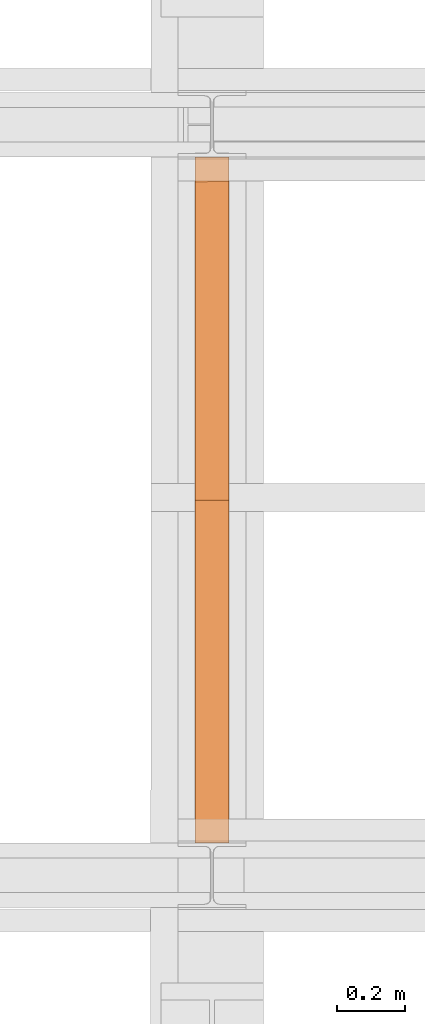
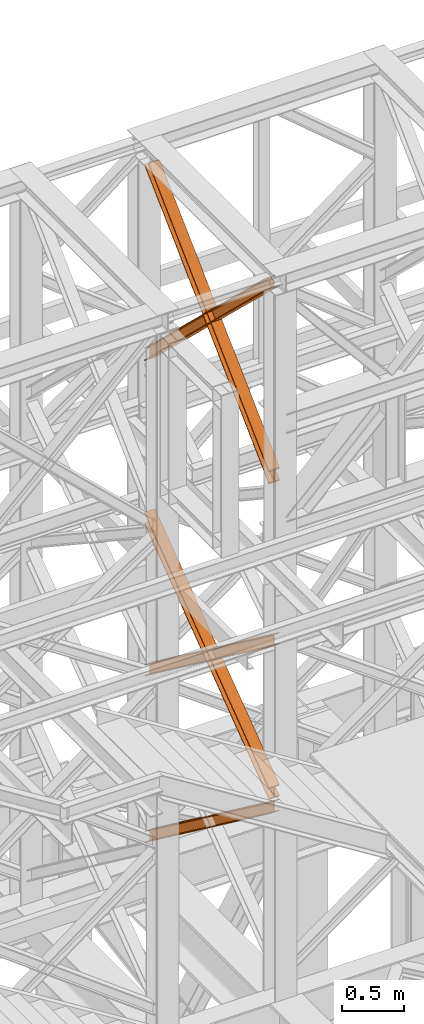
# One storey, part 116 of 208: 5 proxies.
"""IFC2X3 building model written with IfcOpenShell, lengths in millimetres."""

import ifcopenshell
import ifcopenshell.guid

model = None  # the IFC model being written
_history = None  # IfcOwnerHistory: only IFC2X3 demands one
_inside = {}  # id of a spatial element -> (the spatial element, [elements in it])
_under = {}  # id of a project, library or spatial element -> (it, [spatial elements below it])
_declared = {}  # id of a project -> (the project, [libraries it declares])
_typed = {}  # id of a type object -> (the type object, [elements of that type])
_made_of = {}  # id of a material, layer set ... -> (it, [elements and type objects made of it])


def new_model(schema):
    """Start an empty IFC model of exactly this schema.

    Asked for "IFC4X3", IfcOpenShell would pick the latest addendum, in which some entities
    have other attributes; the version numbers below select the first issue.
    IFC2X3 requires an IfcOwnerHistory on every rooted entity: one is made here for all.
    """
    global model, _history
    if schema == "IFC4X3":
        model = ifcopenshell.file(schema_version=(4, 3, 0, 0))
    else:
        model = ifcopenshell.file(schema=schema)
    _inside.clear()
    _under.clear()
    _declared.clear()
    _typed.clear()
    _made_of.clear()
    _history = None
    if model.schema == "IFC2X3":
        org = make("IfcOrganization", Name="unknown")
        user = make(
            "IfcPersonAndOrganization",
            ThePerson=make("IfcPerson", FamilyName="unknown"),
            TheOrganization=org,
        )
        app = make(
            "IfcApplication",
            ApplicationDeveloper=org,
            Version="unknown",
            ApplicationFullName="unknown",
            ApplicationIdentifier="unknown",
        )
        _history = make(
            "IfcOwnerHistory",
            OwningUser=user,
            OwningApplication=app,
            ChangeAction="ADDED",
            CreationDate=0,
        )
    return model


def make(cls, **values):
    """One entity of the class cls with the attributes given. An attribute that is None is left unset."""
    return model.create_entity(
        cls, **{name: value for name, value in values.items() if value is not None}
    )


def entity(cls, *values):
    """Any entity or typed value of the class cls, its attributes in the order of the schema. None: left unset."""
    e = model.create_entity(cls)
    for i, value in enumerate(values):
        if value is not None:
            e[i] = value
    return e


def rooted(cls, **values):
    """An entity with a GlobalId (a new one), such as an element, a storey or a relation."""
    return make(cls, GlobalId=ifcopenshell.guid.new(), OwnerHistory=_history, **values)


def si_unit(unit_type, name, prefix=None):
    """IfcSIUnit, for example si_unit("LENGTHUNIT", "METRE", prefix="MILLI")."""
    return make("IfcSIUnit", UnitType=unit_type, Prefix=prefix, Name=name)


def converted_unit(unit_type, name, factor, base, dimensions=None, offset=None):
    """IfcConversionBasedUnit, such as the inch: factor (a typed value) times the base unit."""
    return make(
        "IfcConversionBasedUnit"
        if offset is None
        else "IfcConversionBasedUnitWithOffset",
        ConversionOffset=offset,
        Dimensions=None
        if dimensions is None
        else entity("IfcDimensionalExponents", *dimensions),
        UnitType=unit_type,
        Name=name,
        ConversionFactor=make(
            "IfcMeasureWithUnit", ValueComponent=factor, UnitComponent=base
        ),
    )


def assignment(units):
    """IfcUnitAssignment: the units of a project."""
    return None if units is None else make("IfcUnitAssignment", Units=units)


def point(xyz):
    """IfcCartesianPoint."""
    return None if xyz is None else make("IfcCartesianPoint", Coordinates=xyz)


def direction(xyz):
    """IfcDirection."""
    return None if xyz is None else make("IfcDirection", DirectionRatios=xyz)


def frame(location, z_axis=None, x_axis=None):
    """IfcAxis2Placement3D, a coordinate frame: its origin and axes. An axis left out is left unset."""
    return make(
        "IfcAxis2Placement3D",
        Location=point(location),
        Axis=direction(z_axis),
        RefDirection=direction(x_axis),
    )


def origin():
    """The frame at (0, 0, 0) with its axes left unset."""
    return frame((0.0, 0.0, 0.0))


def origin_with_axes():
    """The frame at (0, 0, 0) with the z axis (0, 0, 1) and the x axis (1, 0, 0) written out."""
    return frame((0.0, 0.0, 0.0), z_axis=(0.0, 0.0, 1.0), x_axis=(1.0, 0.0, 0.0))


def place(relative_to, where):
    """IfcLocalPlacement: puts the frame where relative to a parent placement (None: the world)."""
    return make(
        "IfcLocalPlacement", PlacementRelTo=relative_to, RelativePlacement=where
    )


def context(
    kind, dimensions, precision=None, world=None, true_north=None, identifier=None
):
    """IfcGeometricRepresentationContext, for example the 3D "Model" context."""
    return make(
        "IfcGeometricRepresentationContext",
        ContextIdentifier=identifier,
        ContextType=kind,
        CoordinateSpaceDimension=dimensions,
        Precision=precision,
        WorldCoordinateSystem=world,
        TrueNorth=true_north,
    )


def subcontext(parent, identifier, kind, view, scale=None):
    """IfcGeometricRepresentationSubContext, for example "Body" below "Model"."""
    return make(
        "IfcGeometricRepresentationSubContext",
        ContextIdentifier=identifier,
        ContextType=kind,
        ParentContext=parent,
        TargetScale=scale,
        TargetView=view,
    )


def project(units=None, contexts=None):
    """IfcProject with its units and contexts."""
    return rooted(
        "IfcProject",
        Name="project",
        RepresentationContexts=contexts,
        UnitsInContext=assignment(units),
    )


def spatial(cls, under=None, at=None, **own):
    """A site, building, storey or space (cls), placed at a placement, below another one or the project."""
    s = rooted(cls, ObjectPlacement=at, **own)
    if under is not None:
        _under.setdefault(under.id(), (under, []))[1].append(s)
    return s


def faces_of(points, faces, orient=None, outer=None):
    """IfcFace entities. A face is a list of loops; a loop is a list of indices into points, from 0.

    orient and outer hold one flag for each loop. By default every Orientation is true, the
    first loop of a face is its IfcFaceOuterBound and the others are IfcFaceBound.
    """
    made = []
    for i, loops in enumerate(faces):
        bounds = []
        for j, loop in enumerate(loops):
            is_outer = j == 0 if outer is None else outer[i][j]
            bounds.append(
                make(
                    "IfcFaceOuterBound" if is_outer else "IfcFaceBound",
                    Bound=make("IfcPolyLoop", Polygon=[points[k] for k in loop]),
                    Orientation=True if orient is None else orient[i][j],
                )
            )
        made.append(make("IfcFace", Bounds=bounds))
    return made


def faceted_brep(points, faces, orient=None, outer=None, voids=None):
    """IfcFacetedBrep: a solid bounded by flat faces; with voids (closed shells), ...WithVoids."""
    shared = [point(p) for p in points]
    hull = make("IfcClosedShell", CfsFaces=faces_of(shared, faces, orient, outer))
    if voids is None:
        return make("IfcFacetedBrep", Outer=hull)
    return make(
        "IfcFacetedBrepWithVoids",
        Outer=hull,
        Voids=[
            make(cls, CfsFaces=faces_of(shared, fs, o, b)) for cls, fs, o, b in voids
        ],
    )


def shape(context_of_items, identifier, shape_type, items):
    """IfcShapeRepresentation: the items that make up one representation, for example the "Body"."""
    return make(
        "IfcShapeRepresentation",
        ContextOfItems=context_of_items,
        RepresentationIdentifier=identifier,
        RepresentationType=shape_type,
        Items=items,
    )


def made_of(thing, what):
    """Note that an element or type object is made of a material, layer set ...; save() writes the relation."""
    if what is not None:
        _made_of.setdefault(what.id(), (what, []))[1].append(thing)
    return thing


def element(
    cls,
    number,
    at=None,
    inside=None,
    cuts=None,
    type_object=None,
    material=None,
    context=None,
    identifier="Body",
    shape_type=None,
    held_by="IfcProductDefinitionShape",
    body=None,
    shapes=None,
    **own,
):
    """One element of the class cls, such as IfcWall. Its Tag is "e" and its number.

    at: its placement. inside: the storey or other place that contains it. cuts: it is an
    opening in that element (IfcRelVoidsElement). A single representation is given by context,
    identifier, shape_type and body (its items); several are given by shapes. held_by: the class
    of the entity that holds the representations. save() writes the other relations.
    """
    e = rooted(cls, Tag="e%d" % number, ObjectPlacement=at, **own)
    if body is not None:
        shapes = [shape(context, identifier, shape_type, body)]
    if shapes is not None:
        e.Representation = make(held_by, Representations=shapes)
    if inside is not None:
        _inside.setdefault(inside.id(), (inside, []))[1].append(e)
    if cuts is not None:
        rooted(
            "IfcRelVoidsElement", RelatingBuildingElement=cuts, RelatedOpeningElement=e
        )
    if type_object is not None:
        _typed.setdefault(type_object.id(), (type_object, []))[1].append(e)
    return made_of(e, material)


def aggregate(whole, parts):
    """IfcRelAggregates: a whole, such as a stair, and the parts it consists of."""
    return rooted("IfcRelAggregates", RelatingObject=whole, RelatedObjects=parts)


def save(model, path):
    """Write the relations noted so far, then the file.

    IfcRelAggregates (storeys below a building ...), IfcRelContainedInSpatialStructure (elements
    in a storey), IfcRelDefinesByType, IfcRelAssociatesMaterial and IfcRelDeclares: one each for
    every whole, place, type object, material and project.
    """
    for whole, parts in _under.values():
        aggregate(whole, parts)
    for where, things in _inside.values():
        rooted(
            "IfcRelContainedInSpatialStructure",
            RelatedElements=things,
            RelatingStructure=where,
        )
    for kind, things in _typed.values():
        rooted("IfcRelDefinesByType", RelatedObjects=things, RelatingType=kind)
    for what, things in _made_of.values():
        rooted("IfcRelAssociatesMaterial", RelatedObjects=things, RelatingMaterial=what)
    for by, libraries in _declared.values():
        rooted("IfcRelDeclares", RelatingContext=by, RelatedDefinitions=libraries)
    model.write(path)


model = new_model("IFC2X3")

# Units and contexts
model_context = context("Model", 3, precision=1e-05, world=origin())
plan_context = context("Plan", 3, precision=1e-05, world=origin())
body_context = subcontext(model_context, "Body", "Model", "MODEL_VIEW")
ifc_project = project(units=[si_unit("LENGTHUNIT", "METRE", prefix="MILLI"), converted_unit("PLANEANGLEUNIT", "DEGREE", entity("IfcPlaneAngleMeasure", 0.0174532925199433), si_unit("PLANEANGLEUNIT", "RADIAN"), dimensions=[0, 0, 0, 0, 0, 0, 0]), si_unit("AREAUNIT", "SQUARE_METRE"), si_unit("VOLUMEUNIT", "CUBIC_METRE")], contexts=[model_context, plan_context])

# Building, storey
building_placement = place(None, origin())
building = spatial("IfcBuilding", under=ifc_project, at=building_placement, CompositionType="COMPLEX")
storey_placement = place(building_placement, origin_with_axes())
storey = spatial("IfcBuildingStorey", under=building, at=storey_placement, Name="Geschoss", CompositionType="ELEMENT")

# Proxies
proxy_1_placement = place(storey_placement, frame((-56.91732335742177, -15867.5743840594, 5504.219540188055), z_axis=(0.0, 0.0, 1.0), x_axis=(1.0, 0.0, 0.0)))
element("IfcBuildingElementProxy", 1, at=proxy_1_placement, inside=storey, context=body_context, shape_type="Brep", body=[
    faceted_brep([(100.0218596475404, 0.01000000000021828, 1511.076608371926), (100.1844513161011, 2010.009987483025, 9.820176864343011), (100.1855295209296, 2010.009987483025, 0.02100513655932446), (100.022937852367, 0.01000000000021828, 1501.277436644132), (100.022937852367, 0.01000000000021828, 1501.277436644132), (100.1855295209296, 2010.009987483025, 0.02100513655932446), (0.1855301264911375, 2010.009987483025, 0.01000000000021828), (0.02293845793224847, 0.01000000000021828, 1501.266431507576), (0.02293845793224847, 0.01000000000021828, 1501.266431507576), (0.1855301264911375, 2010.009987483025, 0.01000000000021828), (0.1844519216663301, 2010.009987483025, 9.809171727787543), (0.02186025310380302, 0.01000000000021828, 1511.06560323536), (0.02186025310380302, 0.01000000000021828, 1511.06560323536), (0.1844519216663301, 2010.009987483025, 9.809171727787543), (47.68445163402408, 2010.009987483025, 9.814399167646116), (47.52185996546337, 0.01000000000021828, 1511.070830675226), (47.52185996546337, 0.01000000000021828, 1511.070830675226), (47.68445163402408, 2010.009987483025, 9.814399167646116), (47.67366958574508, 2010.009987483025, 107.8061164454975), (47.51107791718437, 0.01000000000021828, 1609.062547953077), (47.51107791718437, 0.01000000000021828, 1609.062547953077), (47.67366958574508, 2010.009987483025, 107.8061164454975), (0.1736698733891515, 2010.009987483025, 107.8008890056317), (0.01107820482844346, 0.01000000000021828, 1609.057320513211), (0.01107820482844346, 0.01000000000021828, 1609.057320513211), (0.1736698733891515, 2010.009987483025, 107.8008890056317), (0.1725916685607061, 2010.009987483025, 117.6000607334227), (0.00999999999999801, 0.01000000000021828, 1618.856492240995), (0.00999999999999801, 0.01000000000021828, 1618.856492240995), (0.1725916685607061, 2010.009987483025, 117.6000607334227), (100.1725910629973, 2010.009987483025, 117.6110658699781), (100.0099993944348, 0.01000000000021828, 1618.867497377558), (100.0099993944348, 0.01000000000021828, 1618.867497377558), (100.1725910629973, 2010.009987483025, 117.6110658699781), (100.1736692678239, 2010.009987483025, 107.8118941421981), (100.0110775992632, 0.01000000000021828, 1609.068325649774), (100.0110775992632, 0.01000000000021828, 1609.068325649774), (100.1736692678239, 2010.009987483025, 107.8118941421981), (52.67366955546437, 2010.009987483025, 107.806666702325), (52.51107788690366, 0.01000000000021828, 1609.063098209905), (52.51107788690366, 0.01000000000021828, 1609.063098209905), (52.67366955546437, 2010.009987483025, 107.806666702325), (52.68445160374518, 2010.009987483025, 9.814949424477163), (52.52185993518265, 0.01000000000021828, 1511.071380932057), (52.52185993518265, 0.01000000000021828, 1511.071380932057), (52.68445160374518, 2010.009987483025, 9.814949424477163), (100.1844513161011, 2010.009987483025, 9.820176864343011), (100.0218596475404, 0.01000000000021828, 1511.076608371926), (100.1844513161011, 2010.009987483025, 9.820176864343011), (52.68445160374518, 2010.009987483025, 9.814949424477163), (52.67366955546437, 2010.009987483025, 107.806666702325), (100.1736692678239, 2010.009987483025, 107.8118941421981), (100.1725910629973, 2010.009987483025, 117.6110658699781), (0.1725916685607061, 2010.009987483025, 117.6000607334227), (0.1736698733891515, 2010.009987483025, 107.8008890056317), (47.67366958574508, 2010.009987483025, 107.8061164454975), (47.68445163402408, 2010.009987483025, 9.814399167646116), (0.1844519216663301, 2010.009987483025, 9.809171727787543), (0.1855301264911375, 2010.009987483025, 0.01000000000021828), (100.1855295209296, 2010.009987483025, 0.02100513655932446), (100.022937852367, 0.01000000000021828, 1501.277436644132), (0.02293845793224847, 0.01000000000021828, 1501.266431507576), (0.02186025310380302, 0.01000000000021828, 1511.06560323536), (47.52185996546337, 0.01000000000021828, 1511.070830675226), (47.51107791718437, 0.01000000000021828, 1609.062547953077), (0.01107820482844346, 0.01000000000021828, 1609.057320513211), (0.00999999999999801, 0.01000000000021828, 1618.856492240995), (100.0099993944348, 0.01000000000021828, 1618.867497377558), (100.0110775992632, 0.01000000000021828, 1609.068325649774), (52.51107788690366, 0.01000000000021828, 1609.063098209905), (52.52185993518265, 0.01000000000021828, 1511.071380932057), (100.0218596475404, 0.01000000000021828, 1511.076608371926)], [[[0, 1, 2, 3]], [[4, 5, 6, 7]], [[8, 9, 10, 11]], [[12, 13, 14, 15]], [[16, 17, 18, 19]], [[20, 21, 22, 23]], [[24, 25, 26, 27]], [[28, 29, 30, 31]], [[32, 33, 34, 35]], [[36, 37, 38, 39]], [[40, 41, 42, 43]], [[44, 45, 46, 47]], [[48, 49, 50, 51, 52, 53, 54, 55, 56, 57, 58, 59]], [[60, 61, 62, 63, 64, 65, 66, 67, 68, 69, 70, 71]]], orient=[[False], [False], [False], [False], [False], [False], [False], [False], [False], [False], [False], [False], [False], [False]]),
])
proxy_2_placement = place(storey_placement, frame((-57.10452464362403, -15867.5743840594, 7147.441290649187), z_axis=(0.0, 0.0, 1.0), x_axis=(1.0, 0.0, 0.0)))
element("IfcBuildingElementProxy", 2, at=proxy_2_placement, inside=storey, context=body_context, shape_type="Brep", body=[
    faceted_brep([(100.021862302561, 0.01000000000021828, 1512.063556389601), (100.1844166626904, 2010.009987483025, 9.822513400360549), (100.185495108886, 2010.009987483025, 0.02100513655932446), (100.0229407487548, 0.01000000000021828, 1502.262048125804), (100.0229407487548, 0.01000000000021828, 1502.262048125804), (100.185495108886, 2010.009987483025, 0.02100513655932446), (0.1854957144512426, 2010.009987483025, 0.01000000000021828), (0.02294135431817068, 0.01000000000021828, 1502.251042989237), (0.02294135431817068, 0.01000000000021828, 1502.251042989237), (0.1854957144512426, 2010.009987483025, 0.01000000000021828), (0.1844172682556362, 2010.009987483025, 9.811508263797805), (0.02186290812620229, 0.01000000000021828, 1512.052551253039), (0.02186290812620229, 0.01000000000021828, 1512.052551253039), (0.1844172682556362, 2010.009987483025, 9.811508263797805), (47.68441698061339, 2010.009987483025, 9.816735703663653), (47.52186262048213, 0.01000000000021828, 1512.057778692908), (47.52186262048213, 0.01000000000021828, 1512.057778692908), (47.68441698061339, 2010.009987483025, 9.816735703663653), (47.67363251868461, 2010.009987483025, 107.8318183416577), (47.51107815855153, 0.01000000000021828, 1610.072861330906), (47.51107815855153, 0.01000000000021828, 1610.072861330906), (47.67363251868461, 2010.009987483025, 107.8318183416577), (0.1736328063250383, 2010.009987483025, 107.8265909017955), (0.01107844619560439, 0.01000000000021828, 1610.067633891033), (0.01107844619560439, 0.01000000000021828, 1610.067633891033), (0.1736328063250383, 2010.009987483025, 107.8265909017955), (0.1725543601312509, 2010.009987483025, 117.6280991655931), (0.00999999999999801, 0.01000000000021828, 1619.86914215483), (0.00999999999999801, 0.01000000000021828, 1619.86914215483), (0.1725543601312509, 2010.009987483025, 117.6280991655931), (100.172553754566, 2010.009987483025, 117.6391043021558), (100.0099993944348, 0.01000000000021828, 1619.880147291397), (100.0099993944348, 0.01000000000021828, 1619.880147291397), (100.172553754566, 2010.009987483025, 117.6391043021558), (100.1736322007616, 2010.009987483025, 107.8375960383546), (100.0110778406304, 0.01000000000021828, 1610.078639027603), (100.0110778406304, 0.01000000000021828, 1610.078639027603), (100.1736322007616, 2010.009987483025, 107.8375960383546), (52.67363248840389, 2010.009987483025, 107.8323685984888), (52.51107812827446, 0.01000000000021828, 1610.073411587733), (52.51107812827446, 0.01000000000021828, 1610.073411587733), (52.67363248840389, 2010.009987483025, 107.8323685984888), (52.68441695033449, 2010.009987483025, 9.817285960491063), (52.52186259020323, 0.01000000000021828, 1512.058328949732), (52.52186259020323, 0.01000000000021828, 1512.058328949732), (52.68441695033449, 2010.009987483025, 9.817285960491063), (100.1844166626904, 2010.009987483025, 9.822513400360549), (100.021862302561, 0.01000000000021828, 1512.063556389601), (100.1844166626904, 2010.009987483025, 9.822513400360549), (52.68441695033449, 2010.009987483025, 9.817285960491063), (52.67363248840389, 2010.009987483025, 107.8323685984888), (100.1736322007616, 2010.009987483025, 107.8375960383546), (100.172553754566, 2010.009987483025, 117.6391043021558), (0.1725543601312509, 2010.009987483025, 117.6280991655931), (0.1736328063250383, 2010.009987483025, 107.8265909017955), (47.67363251868461, 2010.009987483025, 107.8318183416577), (47.68441698061339, 2010.009987483025, 9.816735703663653), (0.1844172682556362, 2010.009987483025, 9.811508263797805), (0.1854957144512426, 2010.009987483025, 0.01000000000021828), (100.185495108886, 2010.009987483025, 0.02100513655932446), (100.0229407487548, 0.01000000000021828, 1502.262048125804), (0.02294135431817068, 0.01000000000021828, 1502.251042989237), (0.02186290812620229, 0.01000000000021828, 1512.052551253039), (47.52186262048213, 0.01000000000021828, 1512.057778692908), (47.51107815855153, 0.01000000000021828, 1610.072861330906), (0.01107844619560439, 0.01000000000021828, 1610.067633891033), (0.00999999999999801, 0.01000000000021828, 1619.86914215483), (100.0099993944348, 0.01000000000021828, 1619.880147291397), (100.0110778406304, 0.01000000000021828, 1610.078639027603), (52.51107812827446, 0.01000000000021828, 1610.073411587733), (52.52186259020323, 0.01000000000021828, 1512.058328949732), (100.021862302561, 0.01000000000021828, 1512.063556389601)], [[[0, 1, 2, 3]], [[4, 5, 6, 7]], [[8, 9, 10, 11]], [[12, 13, 14, 15]], [[16, 17, 18, 19]], [[20, 21, 22, 23]], [[24, 25, 26, 27]], [[28, 29, 30, 31]], [[32, 33, 34, 35]], [[36, 37, 38, 39]], [[40, 41, 42, 43]], [[44, 45, 46, 47]], [[48, 49, 50, 51, 52, 53, 54, 55, 56, 57, 58, 59]], [[60, 61, 62, 63, 64, 65, 66, 67, 68, 69, 70, 71]]], orient=[[False], [False], [False], [False], [False], [False], [False], [False], [False], [False], [False], [False], [False], [False]]),
])
proxy_3_placement = place(storey_placement, frame((-57.1043524045706, -15867.5743840594, 7147.394064575148), z_axis=(0.0, 0.0, 1.0), x_axis=(1.0, 0.0, 0.0)))
element("IfcBuildingElementProxy", 3, at=proxy_3_placement, inside=storey, context=body_context, shape_type="Brep", body=[
    faceted_brep([(100.0229386519511, 2010.009987483025, 1501.524522111415), (100.1855729074957, 0.01000000000021828, 0.02100513656296243), (100.1844946360359, 0.01000000000021828, 9.82075546136366), (100.0218603804913, 2010.009987483025, 1511.324272436212), (0.02293925751633452, 2010.009987483025, 1501.513516974852), (0.1855735130591327, 0.01000000000021828, 0.01000000000021828), (100.1855729074957, 0.01000000000021828, 0.02100513656296243), (100.0229386519511, 2010.009987483025, 1501.524522111415), (0.02186098605466924, 2010.009987483025, 1511.313267299649), (0.1844952415992864, 0.01000000000021828, 9.809750324800916), (0.1855735130591327, 0.01000000000021828, 0.01000000000021828), (0.02293925751633452, 2010.009987483025, 1501.513516974852), (47.52186069841242, 2010.009987483025, 1511.318494739518), (47.68449495395522, 0.01000000000021828, 9.814977764666764), (0.1844952415992864, 0.01000000000021828, 9.809750324800916), (0.02186098605466924, 2010.009987483025, 1511.313267299649), (47.51107798381396, 2010.009987483025, 1609.315997987507), (47.67371223936039, 0.01000000000021828, 107.8124810126556), (47.68449495395522, 0.01000000000021828, 9.814977764666764), (47.52186069841242, 2010.009987483025, 1511.318494739518), (0.0110782714598443, 2010.009987483025, 1609.310770547641), (0.1737125270026425, 0.01000000000021828, 107.8072535727861), (47.67371223936039, 0.01000000000021828, 107.8124810126556), (47.51107798381396, 2010.009987483025, 1609.315997987507), (0.00999999999999801, 2010.009987483025, 1619.110520872438), (0.1726342555446152, 0.01000000000021828, 117.6070038975868), (0.1737125270026425, 0.01000000000021828, 107.8072535727861), (0.0110782714598443, 2010.009987483025, 1609.310770547641), (100.0099993944348, 2010.009987483025, 1619.121526009001), (100.1726336499776, 0.01000000000021828, 117.6180090341495), (0.1726342555446152, 0.01000000000021828, 117.6070038975868), (0.00999999999999801, 2010.009987483025, 1619.110520872438), (100.0110776658946, 2010.009987483025, 1609.321775684197), (100.1737119214374, 0.01000000000021828, 107.8182587093452), (100.1726336499776, 0.01000000000021828, 117.6180090341495), (100.0099993944348, 2010.009987483025, 1619.121526009001), (52.51107795353688, 2010.009987483025, 1609.316548244331), (52.67371220908331, 0.01000000000021828, 107.8130312694793), (100.1737119214374, 0.01000000000021828, 107.8182587093452), (100.0110776658946, 2010.009987483025, 1609.321775684197), (52.52186066813352, 2010.009987483025, 1511.319044996339), (52.68449492367996, 0.01000000000021828, 9.815528021497812), (52.67371220908331, 0.01000000000021828, 107.8130312694793), (52.51107795353688, 2010.009987483025, 1609.316548244331), (100.0218603804913, 2010.009987483025, 1511.324272436212), (100.1844946360359, 0.01000000000021828, 9.82075546136366), (52.68449492367996, 0.01000000000021828, 9.815528021497812), (52.52186066813352, 2010.009987483025, 1511.319044996339), (100.1855729074957, 0.01000000000021828, 0.02100513656296243), (0.1855735130591327, 0.01000000000021828, 0.01000000000021828), (0.1844952415992864, 0.01000000000021828, 9.809750324800916), (47.68449495395522, 0.01000000000021828, 9.814977764666764), (47.67371223936039, 0.01000000000021828, 107.8124810126556), (0.1737125270026425, 0.01000000000021828, 107.8072535727861), (0.1726342555446152, 0.01000000000021828, 117.6070038975868), (100.1726336499776, 0.01000000000021828, 117.6180090341495), (100.1737119214374, 0.01000000000021828, 107.8182587093452), (52.67371220908331, 0.01000000000021828, 107.8130312694793), (52.68449492367996, 0.01000000000021828, 9.815528021497812), (100.1844946360359, 0.01000000000021828, 9.82075546136366), (100.0218603804913, 2010.009987483025, 1511.324272436212), (52.52186066813352, 2010.009987483025, 1511.319044996339), (52.51107795353688, 2010.009987483025, 1609.316548244331), (100.0110776658946, 2010.009987483025, 1609.321775684197), (100.0099993944348, 2010.009987483025, 1619.121526009001), (0.00999999999999801, 2010.009987483025, 1619.110520872438), (0.0110782714598443, 2010.009987483025, 1609.310770547641), (47.51107798381396, 2010.009987483025, 1609.315997987507), (47.52186069841242, 2010.009987483025, 1511.318494739518), (0.02186098605466924, 2010.009987483025, 1511.313267299649), (0.02293925751633452, 2010.009987483025, 1501.513516974852), (100.0229386519511, 2010.009987483025, 1501.524522111415)], [[[0, 1, 2, 3]], [[4, 5, 6, 7]], [[8, 9, 10, 11]], [[12, 13, 14, 15]], [[16, 17, 18, 19]], [[20, 21, 22, 23]], [[24, 25, 26, 27]], [[28, 29, 30, 31]], [[32, 33, 34, 35]], [[36, 37, 38, 39]], [[40, 41, 42, 43]], [[44, 45, 46, 47]], [[48, 49, 50, 51, 52, 53, 54, 55, 56, 57, 58, 59]], [[60, 61, 62, 63, 64, 65, 66, 67, 68, 69, 70, 71]]], orient=[[False], [False], [False], [False], [False], [False], [False], [False], [False], [False], [False], [False], [False], [False]]),
])
proxy_4_placement = place(storey_placement, frame((-57.29073392602709, -15867.57439014891, 10257.71351554296), z_axis=(0.0, 0.0, 1.0), x_axis=(1.0, 0.0, 0.0)))
element("IfcBuildingElementProxy", 4, at=proxy_4_placement, inside=storey, context=body_context, shape_type="Brep", body=[
    faceted_brep([(100.0212045496899, 2010.009993572538, 119.6472293306997), (100.1463438185763, 56.72628223557149, 1992.286543150845), (100.146635060966, 68.07077152448983, 1992.286543150845), (100.0222231921614, 2010.009993572536, 130.5233411127829), (100.0222231921614, 2010.009993572536, 130.5233411127829), (100.146635060966, 68.07077152448983, 1992.286543150845), (0.1466348943756728, 68.08252523311057, 1992.286543150842), (0.02222377857811608, 2010.009993572536, 130.5346095510231), (0.02222377857811608, 2010.009993572536, 130.5346095510231), (0.1466348943756728, 68.08252523311057, 1992.286543150842), (0.1463436519823134, 56.73803594420861, 1992.286543150842), (0.02120513611203734, 2010.009993572536, 119.6584977689327), (0.02120513611203734, 2010.009993572536, 119.6584977689327), (0.1463436519823134, 56.73803594420861, 1992.286543150842), (47.64634373111381, 56.73245293260334, 1992.286543150845), (47.5212048575611, 2010.009993572536, 119.6531452607651), (47.5212048575611, 2010.009993572536, 119.6531452607651), (47.64634373111381, 56.73245293260334, 1992.286543150845), (47.64488761591907, 0.01000608951108006, 1992.286543150845), (47.63979748861653, 0.01000608951108006, 1937.905972056111), (47.51101837541842, 2010.009993572536, 10.89202766673589), (47.51101837541842, 2010.009993572536, 10.89202766673589), (47.63979748861653, 0.01000608951108006, 1937.905972056111), (0.1397977671692914, 0.01000608951108006, 1937.911324564264), (0.01101865397118473, 2010.009993572536, 10.89738017488162), (0.01101865397118473, 2010.009993572536, 10.89738017488162), (0.1397977671692914, 0.01000608951108006, 1937.911324564264), (0.1387797399163517, 0.01000608951108006, 1927.035210352397), (0.00999999999999801, 2010.009993572536, 0.02126843821861257), (0.00999999999999801, 2010.009993572536, 0.02126843821861257), (0.1387797399163517, 0.01000608951108006, 1927.035210352397), (100.138779153496, 0.01000608951108006, 1927.023941914182), (100.009999413576, 2010.009993572536, 0.01000000000021828), (100.009999413576, 2010.009993572536, 0.01000000000021828), (100.138779153496, 0.01000608951108006, 1927.023941914182), (100.1397971807453, 0.01000608951108006, 1937.900056126053), (100.0110180675508, 2010.009993572536, 10.88611173667414), (100.0110180675508, 2010.009993572536, 10.88611173667414), (100.1397971807453, 0.01000608951108006, 1937.900056126053), (52.63979745929806, 0.01000608951108006, 1937.905408634202), (52.51101834609813, 2010.009993572536, 10.89146424482351), (52.51101834609813, 2010.009993572536, 10.89146424482351), (52.63979745929806, 0.01000608951108006, 1937.905408634202), (52.64488763917849, 0.01000000000021828, 1992.286543150845), (52.64634373944296, 56.73186524717494, 1992.286543150845), (52.52120482823899, 2010.009993572536, 119.65258183886), (52.52120482823899, 2010.009993572536, 119.65258183886), (52.64634373944296, 56.73186524717494, 1992.286543150845), (100.1463438185763, 56.72628223557149, 1992.286543150845), (100.0212045496899, 2010.009993572538, 119.6472293306997), (100.1463438185763, 56.72628223557149, 1992.286543150845), (52.64634373944296, 56.73186524717494, 1992.286543150845), (52.64488763917849, 0.01000000000021828, 1992.286543150845), (47.64488761591907, 0.01000608951108006, 1992.286543150845), (47.64634373111381, 56.73245293260334, 1992.286543150845), (0.1463436519823134, 56.73803594420861, 1992.286543150842), (0.1466348943756728, 68.08252523311057, 1992.286543150842), (100.146635060966, 68.07077152448983, 1992.286543150845), (47.64488761591907, 0.01000608951108006, 1992.286543150845), (52.64488763917849, 0.01000000000021828, 1992.286543150845), (52.63979745929806, 0.01000608951108006, 1937.905408634202), (100.1397971807453, 0.01000608951108006, 1937.900056126053), (100.138779153496, 0.01000608951108006, 1927.023941914182), (0.1387797399163517, 0.01000608951108006, 1927.035210352397), (0.1397977671692914, 0.01000608951108006, 1937.911324564264), (47.63979748861653, 0.01000608951108006, 1937.905972056111), (100.0222231921614, 2010.009993572536, 130.5233411127829), (0.02222377857811608, 2010.009993572536, 130.5346095510231), (0.02120513611203734, 2010.009993572536, 119.6584977689327), (47.5212048575611, 2010.009993572536, 119.6531452607651), (47.51101837541842, 2010.009993572536, 10.89202766673589), (0.01101865397118473, 2010.009993572536, 10.89738017488162), (0.00999999999999801, 2010.009993572536, 0.02126843821861257), (100.009999413576, 2010.009993572536, 0.01000000000021828), (100.0110180675508, 2010.009993572536, 10.88611173667414), (52.51101834609813, 2010.009993572536, 10.89146424482351), (52.52120482823899, 2010.009993572536, 119.65258183886), (100.0212045496899, 2010.009993572538, 119.6472293306997)], [[[0, 1, 2, 3]], [[4, 5, 6, 7]], [[8, 9, 10, 11]], [[12, 13, 14, 15]], [[16, 17, 18, 19, 20]], [[21, 22, 23, 24]], [[25, 26, 27, 28]], [[29, 30, 31, 32]], [[33, 34, 35, 36]], [[37, 38, 39, 40]], [[41, 42, 43, 44, 45]], [[46, 47, 48, 49]], [[50, 51, 52, 53, 54, 55, 56, 57]], [[58, 59, 60, 61, 62, 63, 64, 65]], [[66, 67, 68, 69, 70, 71, 72, 73, 74, 75, 76, 77]]], orient=[[False], [False], [False], [False], [False], [False], [False], [False], [False], [False], [False], [False], [False], [False], [False]]),
])
proxy_5_placement = place(storey_placement, frame((-57.27096254627919, -15867.5743840594, 10261.20680675583), z_axis=(0.0, 0.0, 1.0), x_axis=(1.0, 0.0, 0.0)))
element("IfcBuildingElementProxy", 5, at=proxy_5_placement, inside=storey, context=body_context, shape_type="Brep", body=[
    faceted_brep([(100.0219376352104, 0.01000000000021828, 130.5376928144524), (100.124867399614, 1937.888230286315, 1988.793251937981), (100.1244756427457, 1949.231612164787, 1988.793251937985), (100.0209427866555, 0.01000000000021828, 119.6603850577285), (0.02193825011978134, 0.01000000000021828, 130.5496157990219), (0.1248673541028964, 1937.875796424816, 1988.793251937981), (100.124867399614, 1937.888230286315, 1988.793251937981), (100.0219376352104, 0.01000000000021828, 130.5376928144524), (0.02094340156669006, 0.01000000000021828, 119.6723080422798), (0.1244755972309193, 1949.21917830328, 1988.793251937981), (0.1248673541028964, 1937.875796424816, 1988.793251937981), (0.02193825011978134, 0.01000000000021828, 130.5496157990219), (47.52094310948429, 0.01000000000021828, 119.6666446246109), (47.62447561884961, 1949.225084387492, 1988.793251937981), (0.1244755972309193, 1949.21917830328, 1988.793251937981), (0.02094340156669006, 0.01000000000021828, 119.6723080422798), (47.51099456772113, 0.01000000000021828, 10.89356727918312), (47.61776178021297, 2010.009987483025, 1938.307550640491), (47.62237652174532, 2010.009987483025, 1988.793251937981), (47.62447561884961, 1949.225084387492, 1988.793251937981), (47.52094310948429, 0.01000000000021828, 119.6666446246109), (0.01099485980717674, 0.01000000000021828, 10.899230696823), (0.1177620722971895, 2010.009987483025, 1938.313214058149), (47.61776178021297, 2010.009987483025, 1938.307550640491), (47.51099456772113, 0.01000000000021828, 10.89356727918312), (0.00999999999999801, 0.01000000000021828, 0.02192298452973773), (0.1167678252620661, 2010.009987483025, 1927.43590392548), (0.1177620722971895, 2010.009987483025, 1938.313214058149), (0.01099485980717674, 0.01000000000021828, 10.899230696823), (100.0099993850834, 0.01000000000021828, 0.01000000000021828), (100.1167672103491, 2010.009987483025, 1927.42398094095), (0.1167678252620661, 2010.009987483025, 1927.43590392548), (0.00999999999999801, 0.01000000000021828, 0.02192298452973773), (100.0109942448942, 0.01000000000021828, 10.88730771230075), (100.1177614573787, 2010.009987483025, 1938.301291073616), (100.1167672103491, 2010.009987483025, 1927.42398094095), (100.0099993850834, 0.01000000000021828, 0.01000000000021828), (52.51099453697112, 0.01000000000021828, 10.89297112994063), (52.61776174946659, 2010.009987483025, 1938.306954491263), (100.1177614573787, 2010.009987483025, 1938.301291073616), (100.0109942448942, 0.01000000000021828, 10.88730771230075), (52.52094307873609, 0.01000000000021828, 119.6660484753793), (52.62447562112516, 1949.225706080566, 1988.793251937981), (52.6223765454904, 2010.009987483025, 1988.793251937981), (52.61776174946659, 2010.009987483025, 1938.306954491263), (52.51099453697112, 0.01000000000021828, 10.89297112994063), (100.0209427866555, 0.01000000000021828, 119.6603850577285), (100.1244756427457, 1949.231612164787, 1988.793251937985), (52.62447562112516, 1949.225706080566, 1988.793251937981), (52.52094307873609, 0.01000000000021828, 119.6660484753793), (100.124867399614, 1937.888230286315, 1988.793251937981), (0.1248673541028964, 1937.875796424816, 1988.793251937981), (0.1244755972309193, 1949.21917830328, 1988.793251937981), (47.62447561884961, 1949.225084387492, 1988.793251937981), (47.62237652174532, 2010.009987483025, 1988.793251937981), (52.6223765454904, 2010.009987483025, 1988.793251937981), (52.62447562112516, 1949.225706080566, 1988.793251937981), (100.1244756427457, 1949.231612164787, 1988.793251937985), (47.62237652174532, 2010.009987483025, 1988.793251937981), (47.61776178021297, 2010.009987483025, 1938.307550640491), (0.1177620722971895, 2010.009987483025, 1938.313214058149), (0.1167678252620661, 2010.009987483025, 1927.43590392548), (100.1167672103491, 2010.009987483025, 1927.42398094095), (100.1177614573787, 2010.009987483025, 1938.301291073616), (52.61776174946659, 2010.009987483025, 1938.306954491263), (52.6223765454904, 2010.009987483025, 1988.793251937981), (100.0209427866555, 0.01000000000021828, 119.6603850577285), (52.52094307873609, 0.01000000000021828, 119.6660484753793), (52.51099453697112, 0.01000000000021828, 10.89297112994063), (100.0109942448942, 0.01000000000021828, 10.88730771230075), (100.0099993850834, 0.01000000000021828, 0.01000000000021828), (0.00999999999999801, 0.01000000000021828, 0.02192298452973773), (0.01099485980717674, 0.01000000000021828, 10.899230696823), (47.51099456772113, 0.01000000000021828, 10.89356727918312), (47.52094310948429, 0.01000000000021828, 119.6666446246109), (0.02094340156669006, 0.01000000000021828, 119.6723080422798), (0.02193825011978134, 0.01000000000021828, 130.5496157990219), (100.0219376352104, 0.01000000000021828, 130.5376928144524)], [[[0, 1, 2, 3]], [[4, 5, 6, 7]], [[8, 9, 10, 11]], [[12, 13, 14, 15]], [[16, 17, 18, 19, 20]], [[21, 22, 23, 24]], [[25, 26, 27, 28]], [[29, 30, 31, 32]], [[33, 34, 35, 36]], [[37, 38, 39, 40]], [[41, 42, 43, 44, 45]], [[46, 47, 48, 49]], [[50, 51, 52, 53, 54, 55, 56, 57]], [[58, 59, 60, 61, 62, 63, 64, 65]], [[66, 67, 68, 69, 70, 71, 72, 73, 74, 75, 76, 77]]], orient=[[False], [False], [False], [False], [False], [False], [False], [False], [False], [False], [False], [False], [False], [False], [False]]),
])

save(model, "model.ifc")
